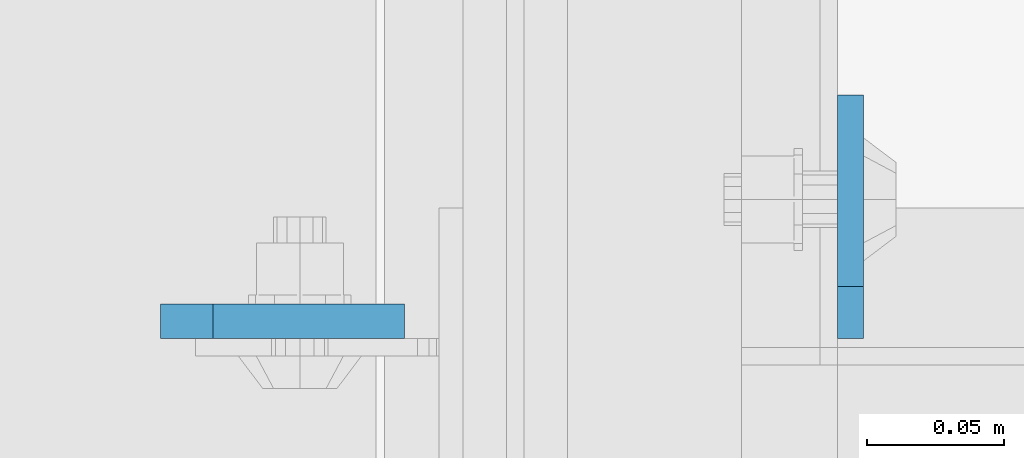
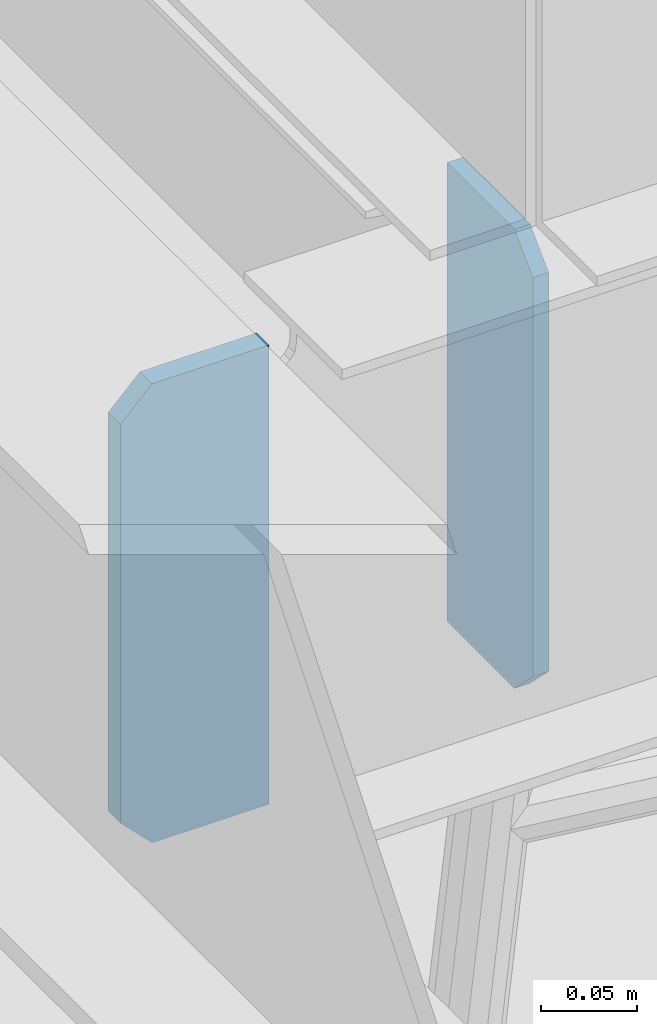
# One storey, part 1428 of 1876: 2 plates, 2 elements without a shape of their own.
"""IFC2X3 building model written with IfcOpenShell, lengths in millimetres."""

from ifc_helpers import new_model, si_unit, frame, origin_with_axes, place, context, subcontext, project, spatial, faceted_brep, material, type_object, element, aggregate, save


model = new_model("IFC2X3")

# Units and contexts
model_context = context("Model", 3, precision=1e-05, world=origin_with_axes())
body_context = subcontext(model_context, "Body", "Model", "MODEL_VIEW")
ifc_project = project(units=[si_unit("LENGTHUNIT", "METRE", prefix="MILLI"), si_unit("AREAUNIT", "SQUARE_METRE"), si_unit("VOLUMEUNIT", "CUBIC_METRE"), si_unit("MASSUNIT", "GRAM", prefix="KILO"), si_unit("TIMEUNIT", "SECOND"), si_unit("PLANEANGLEUNIT", "RADIAN"), si_unit("SOLIDANGLEUNIT", "STERADIAN"), si_unit("THERMODYNAMICTEMPERATUREUNIT", "DEGREE_CELSIUS"), si_unit("LUMINOUSINTENSITYUNIT", "LUMEN")], contexts=[model_context])

# Site, building, storey
site_placement = place(None, origin_with_axes())
site = spatial("IfcSite", under=ifc_project, at=site_placement, CompositionType="ELEMENT")
building_placement = place(site_placement, origin_with_axes())
building = spatial("IfcBuilding", under=site, at=building_placement, Name="Undefined", CompositionType="ELEMENT")
storey_placement = place(building_placement, origin_with_axes())
storey = spatial("IfcBuildingStorey", under=building, at=storey_placement, Name="Undefined", CompositionType="ELEMENT", Elevation=0.0)

# Assembly, plate
assembly_1_placement = place(storey_placement, origin_with_axes())
assembly_1 = element("IfcElementAssembly", 1, at=assembly_1_placement, inside=storey, Name="BEAM", AssemblyPlace="NOTDEFINED", PredefinedType="RIGID_FRAME")
ifc_material = material(Name="STEEL/A36")
plate_type_1 = type_object("IfcPlateType", PredefinedType="NOTDEFINED")
plate_1_placement = place(assembly_1_placement, frame((1208.0875, -6245.225, 22258.3375), z_axis=(0.0, 0.0, 1.0), x_axis=(0.0, 1.0, 0.0)))
plate_1 = element("IfcPlate", 2, at=plate_1_placement, type_object=plate_type_1, material=ifc_material, Name="PLATE", context=body_context, shape_type="Brep", body=[
    faceted_brep([(0.0, -4.76249999999982, 19.0499992370605), (0.0, -4.76249999999982, 271.462512969971), (0.0, 4.76249999999982, 271.462512969971), (0.0, 4.76249999999982, 19.0499992370605), (19.0499992370605, -4.76249999999982, 290.512512207031), (19.0499992370605, 4.76249999999982, 290.512512207031), (88.9000015258789, -4.76249999999982, 290.512512207031), (88.9000015258789, 4.76249999999982, 290.512512207031), (88.9000015258789, -4.76249999999982, 0.0), (88.9000015258789, 4.76249999999982, 0.0), (19.0499992370605, -4.76249999999982, 0.0), (19.0499992370605, 4.76249999999982, 0.0)], [[[0, 1, 2, 3]], [[1, 4, 5, 2]], [[4, 6, 7, 5]], [[6, 8, 9, 7]], [[8, 10, 11, 9]], [[10, 0, 3, 11]], [[5, 7, 9, 11, 3, 2]], [[10, 8, 6, 4, 1, 0]]]),
])
aggregate(assembly_1, [plate_1])

assembly_2_placement = place(storey_placement, origin_with_axes())
assembly_2 = element("IfcElementAssembly", 3, at=assembly_2_placement, inside=storey, Name="BEAM", AssemblyPlace="NOTDEFINED", PredefinedType="RIGID_FRAME")
plate_type_2 = type_object("IfcPlateType", PredefinedType="NOTDEFINED")
plate_2_placement = place(assembly_2_placement, frame((956.46875, -6238.87499990463, 22251.9874999699), z_axis=(0.0, 0.0, 1.0), x_axis=(1.0, 0.0, 0.0)))
plate_2 = element("IfcPlate", 4, at=plate_2_placement, type_object=plate_type_2, material=ifc_material, Name="PLATE", context=body_context, shape_type="Brep", body=[
    faceted_brep([(0.0, -6.35000000000196, 19.0499992370605), (0.0, -6.35000000000036, 271.462512969971), (0.0, 6.35000000000036, 271.462512969971), (0.0, 6.35000000000105, 19.0499992370605), (19.0499992370605, -6.35000000000036, 290.512512207031), (19.0499992370605, 6.35000000000036, 290.512512207031), (88.9000015258789, -6.35000000000036, 290.512512207031), (88.9000015258789, 6.35000000000036, 290.512512207031), (88.9000015258789, -6.34999999999991, 0.0), (88.9000015258789, 6.34999999999991, 0.0), (19.0499992370642, -6.35000000000105, 0.0), (19.0499992370633, 6.35000000000105, 0.0)], [[[0, 1, 2, 3]], [[1, 4, 5, 2]], [[4, 6, 7, 5]], [[6, 8, 9, 7]], [[8, 10, 11, 9]], [[10, 0, 3, 11]], [[5, 7, 9, 11, 3, 2]], [[10, 8, 6, 4, 1, 0]]]),
])
aggregate(assembly_2, [plate_2])

save(model, "model.ifc")
